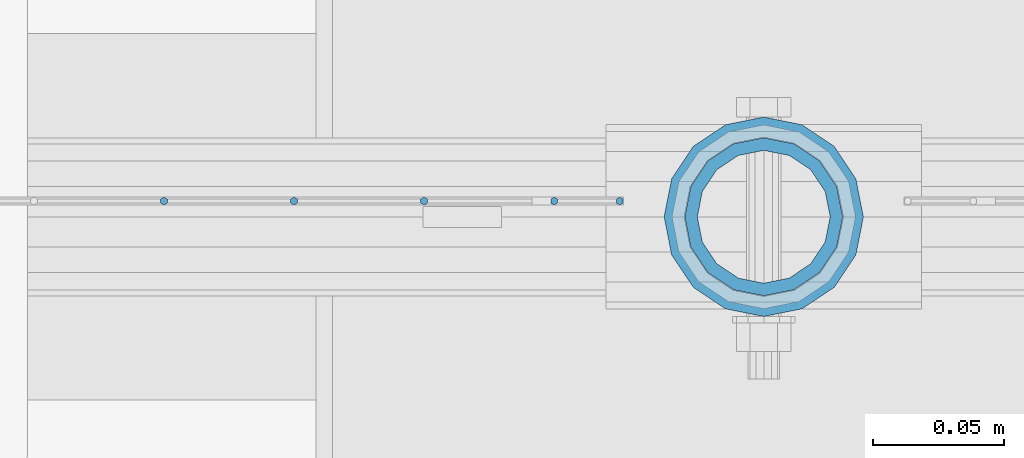
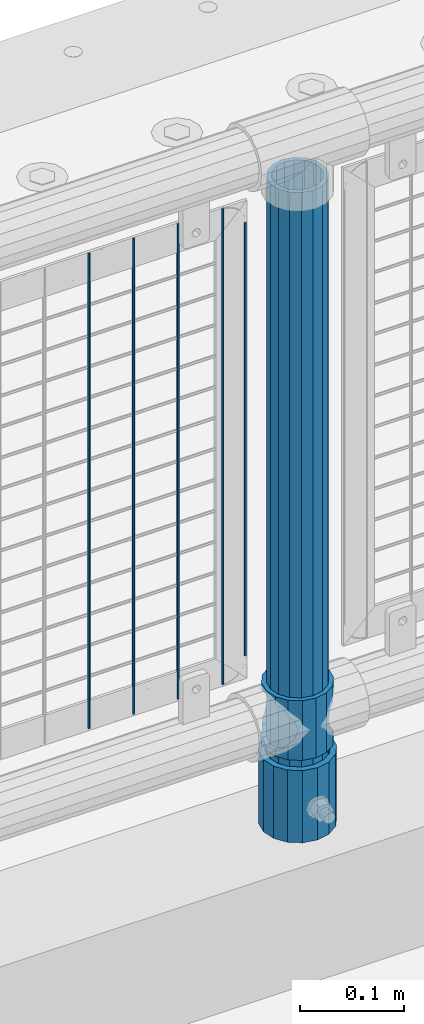
# One storey, part 68 of 257: 8 columns.
"""IFC2X3 building model written with IfcOpenShell, lengths in millimetres."""

from ifc_helpers import new_model, si_unit, frame, origin_with_axes, place, context, subcontext, project, spatial, faceted_brep, material, type_object, element, save


model = new_model("IFC2X3")

# Units and contexts
model_context = context("Model", 3, precision=1e-05, world=origin_with_axes())
body_context = subcontext(model_context, "Body", "Model", "MODEL_VIEW")
ifc_project = project(units=[si_unit("LENGTHUNIT", "METRE", prefix="MILLI"), si_unit("AREAUNIT", "SQUARE_METRE"), si_unit("VOLUMEUNIT", "CUBIC_METRE"), si_unit("MASSUNIT", "GRAM", prefix="KILO"), si_unit("TIMEUNIT", "SECOND"), si_unit("PLANEANGLEUNIT", "RADIAN"), si_unit("SOLIDANGLEUNIT", "STERADIAN"), si_unit("THERMODYNAMICTEMPERATUREUNIT", "DEGREE_CELSIUS"), si_unit("LUMINOUSINTENSITYUNIT", "LUMEN")], contexts=[model_context])

# Site, building, storey
site_placement = place(None, origin_with_axes())
site = spatial("IfcSite", under=ifc_project, at=site_placement, CompositionType="ELEMENT")
building_placement = place(site_placement, origin_with_axes())
building = spatial("IfcBuilding", under=site, at=building_placement, Name="Standard", CompositionType="ELEMENT")
storey_placement = place(building_placement, origin_with_axes())
storey = spatial("IfcBuildingStorey", under=building, at=storey_placement, Name="Undefined", CompositionType="ELEMENT", Elevation=0.0)

# Columns
ifc_material_1 = material()
column_type_1 = type_object("IfcColumnType", PredefinedType="NOTDEFINED")
column_1_placement = place(storey_placement, frame((44671.0, 10664.5, 168.02), z_axis=(0.0, 1.0, 0.0), x_axis=(0.0, 0.0, 1.0)))
element("IfcColumn", 1, at=column_1_placement, inside=storey, type_object=column_type_1, material=ifc_material_1, context=body_context, shape_type="Brep", body=[
    faceted_brep([(0.0, -31.75, 0.0), (0.0, -29.3331751572332, 12.1501989775916), (85.0, -29.3331751572332, 12.1501989775916), (85.0, -31.75, 0.0), (0.0, -22.4506403026753, 22.4506403026735), (85.0, -22.4506403026753, 22.4506403026735), (0.0, -12.1501989775934, 29.3331751572332), (85.0, -12.1501989775934, 29.3331751572332), (0.0, 0.0, 31.75), (85.0, 0.0, 31.75), (0.0, 12.1501989775934, 29.3331751572332), (85.0, 12.1501989775934, 29.3331751572332), (0.0, 22.4506403026753, 22.4506403026735), (85.0, 22.4506403026753, 22.4506403026735), (0.0, 29.3331751572332, 12.1501989775916), (85.0, 29.3331751572332, 12.1501989775916), (0.0, 31.75, 0.0), (85.0, 31.75, 0.0), (0.0, 29.3331751572332, -12.1501989775916), (85.0, 29.3331751572332, -12.1501989775916), (0.0, 22.4506403026753, -22.4506403026735), (85.0, 22.4506403026753, -22.4506403026735), (0.0, 12.1501989775934, -29.3331751572332), (85.0, 12.1501989775934, -29.3331751572332), (0.0, 0.0, -31.75), (85.0, 0.0, -31.75), (0.0, -12.1501989775934, -29.3331751572332), (85.0, -12.1501989775934, -29.3331751572332), (0.0, -22.4506403026753, -22.4506403026735), (85.0, -22.4506403026753, -22.4506403026735), (0.0, -29.3331751572332, -12.1501989775916), (85.0, -29.3331751572332, -12.1501989775916), (0.0, -38.0500000000029, 0.0), (0.0, -35.1536162120537, -14.561104601491), (85.0, -35.1536162120537, -14.561104601491), (85.0, -38.0500000000029, 0.0), (0.0, -26.9054130241493, -26.9054130241475), (85.0, -26.9054130241493, -26.9054130241475), (0.0, -14.5611046014892, -35.1536162120537), (85.0, -14.5611046014892, -35.1536162120537), (0.0, 0.0, -38.0499999999993), (85.0, 0.0, -38.0499999999993), (0.0, 14.5611046014892, -35.1536162120537), (85.0, 14.5611046014892, -35.1536162120537), (0.0, 26.9054130241493, -26.9054130241475), (85.0, 26.9054130241493, -26.9054130241475), (0.0, 35.1536162120537, -14.561104601491), (85.0, 35.1536162120537, -14.561104601491), (0.0, 38.0500000000029, 0.0), (85.0, 38.0500000000029, 0.0), (0.0, 35.1536162120537, 14.561104601491), (85.0, 35.1536162120537, 14.561104601491), (0.0, 26.9054130241493, 26.9054130241475), (85.0, 26.9054130241493, 26.9054130241475), (0.0, 14.5611046014892, 35.1536162120537), (85.0, 14.5611046014892, 35.1536162120537), (0.0, 0.0, 38.0499999999993), (85.0, 0.0, 38.0499999999993), (0.0, -14.5611046014892, 35.1536162120537), (85.0, -14.5611046014892, 35.1536162120537), (0.0, -26.9054130241493, 26.9054130241475), (85.0, -26.9054130241493, 26.9054130241475), (0.0, -35.1536162120537, 14.561104601491), (85.0, -35.1536162120537, 14.561104601491)], [[[0, 1, 2, 3]], [[1, 4, 5, 2]], [[4, 6, 7, 5]], [[6, 8, 9, 7]], [[8, 10, 11, 9]], [[10, 12, 13, 11]], [[12, 14, 15, 13]], [[14, 16, 17, 15]], [[16, 18, 19, 17]], [[18, 20, 21, 19]], [[20, 22, 23, 21]], [[22, 24, 25, 23]], [[24, 26, 27, 25]], [[26, 28, 29, 27]], [[28, 30, 31, 29]], [[30, 0, 3, 31]], [[32, 33, 34, 35]], [[33, 36, 37, 34]], [[36, 38, 39, 37]], [[38, 40, 41, 39]], [[40, 42, 43, 41]], [[42, 44, 45, 43]], [[44, 46, 47, 45]], [[46, 48, 49, 47]], [[48, 50, 51, 49]], [[50, 52, 53, 51]], [[52, 54, 55, 53]], [[54, 56, 57, 55]], [[56, 58, 59, 57]], [[58, 60, 61, 59]], [[60, 62, 63, 61]], [[62, 32, 35, 63]], [[37, 39, 41, 43, 45, 47, 49, 51, 53, 55, 57, 59, 61, 63, 35, 34], [5, 7, 9, 11, 13, 15, 17, 19, 21, 23, 25, 27, 29, 31, 3, 2]], [[62, 60, 58, 56, 54, 52, 50, 48, 46, 44, 42, 40, 38, 36, 33, 32], [30, 28, 26, 24, 22, 20, 18, 16, 14, 12, 10, 8, 6, 4, 1, 0]]]),
])
ifc_material_2 = material(Name="Misc_Undefined")
column_type_2 = type_object("IfcColumnType", PredefinedType="NOTDEFINED")
column_2_placement = place(storey_placement, frame((44671.0, 10664.5, 263.02), z_axis=(-1.0, 0.0, 0.0), x_axis=(0.0, 0.0, 1.0)))
element("IfcColumn", 2, at=column_2_placement, inside=storey, type_object=column_type_2, material=ifc_material_2, context=body_context, shape_type="Brep", body=[
    faceted_brep([(63.1897438117172, 11.6144421722802, -32.8397438117245), (63.1897438117172, 11.6144421722802, -28.0397438117143), (56.6106908090114, 21.4606908090118, -21.4606908090136), (56.6106908090114, 21.4606908090118, -27.1226768591077), (61.9623795176756, 13.4513226476338, -32.4743655677739), (46.7644421722801, 28.0397438117179, -11.6144421722784), (46.7644421722801, 28.0397438117179, -20.0882031229921), (51.5310424080039, 24.8548033587067, -24.8548033587067), (35.1500000000015, 30.35, 0.0), (35.1499999999996, 30.3500000000004, -16.6306603983758), (23.5355578277192, 28.0397438117179, -11.6144421722784), (23.5355578277192, 28.0397438117179, -20.0882031229921), (18.7689575919954, 24.8548033587067, -24.8548033587067), (13.6893091909879, 21.4606908090118, -21.4606908090136), (13.6893091909879, 21.4606908090118, -27.1226768591077), (8.3376204823237, 13.4513226476338, -32.4743655677739), (7.11025618828211, 11.6144421722802, -28.0397438117143), (7.11025618828211, 11.6144421722802, -32.8397438117245), (4.79999999999961, 0.0, -30.3499999999985), (4.79999999999961, 0.0, -35.1500000000015), (7.11025618828205, -11.6144421722802, -28.0397438117143), (7.11025618828205, -11.6144421722802, -32.8397438117245), (13.6893091909879, -21.4606908090118, -21.4606908090136), (13.6893091909879, -21.4606908090118, -27.1226768591077), (8.33762048232484, -13.4513226476338, -32.4743655677739), (23.5355578277191, -28.0397438117179, -11.6144421722784), (23.5355578277191, -28.0397438117179, -20.0882031229849), (18.7689575919987, -24.8548033587067, -24.8548033587067), (35.1500000000015, -30.35, 0.0), (35.1499999999996, -30.3500000000004, -16.6306603983685), (46.7644421722801, -28.0397438117179, -11.6144421722784), (46.7644421722801, -28.0397438117179, -20.0882031229849), (51.5310424080038, -24.8548033587067, -24.8548033587067), (56.6106908090114, -21.4606908090118, -21.4606908090136), (56.6106908090114, -21.4606908090118, -27.1226768591077), (61.9623795176756, -13.4513226476338, -32.4743655677739), (63.1897438117172, -11.6144421722802, -28.0397438117143), (63.1897438117172, -11.6144421722802, -32.8397438117245), (65.4999999999997, 0.0, -30.3499999999985), (65.4999999999997, 0.0, -35.1500000000015), (0.0, -28.0397438117179, -11.6144421722784), (0.0, -30.3500000000004, 0.0), (0.0, -21.4606908090118, -21.4606908090136), (0.0, -11.6144421722802, -28.0397438117143), (0.0, 0.0, -30.3499999999985), (0.0, 11.6144421722802, -28.0397438117143), (0.0, 21.4606908090118, -21.4606908090136), (0.0, 28.0397438117179, -11.6144421722784), (0.0, 30.3500000000004, 0.0), (0.0, 28.0397438117179, 11.6144421722784), (23.5355578277192, 28.0397438117179, 11.6144421722784), (0.0, 21.4606908090118, 21.4606908090136), (13.6893091909879, 21.4606908090118, 21.4606908090136), (0.0, 11.6144421722802, 28.0397438117143), (7.11025618828211, 11.6144421722802, 28.0397438117143), (0.0, 0.0, 30.3499999999985), (4.79999999999961, 0.0, 30.3499999999985), (0.0, -11.6144421722802, 28.0397438117143), (7.11025618828205, -11.6144421722802, 28.0397438117143), (0.0, -21.4606908090118, 21.4606908090136), (13.6893091909879, -21.4606908090118, 21.4606908090136), (0.0, -28.0397438117179, 11.6144421722784), (23.5355578277191, -28.0397438117179, 11.6144421722784), (0.0, -32.4743655677721, 13.4513226476338), (0.0, -35.1499999999996, 0.0), (70.2999999999993, -35.1499999999996, 0.0), (70.2999999999993, -32.4743655677721, 13.4513226476338), (0.0, 13.4513226476338, -32.4743655677739), (0.0, 24.8548033587067, -24.8548033587067), (0.0, 0.0, -35.1499999999996), (0.0, -13.4513226476338, -32.4743655677739), (0.0, -24.8548033587067, -24.8548033587067), (0.0, -24.8548033587067, 24.8548033587067), (0.0, -13.4513226476338, 32.4743655677739), (0.0, 0.0, 35.1499999999996), (0.0, 13.4513226476338, 32.4743655677739), (0.0, 24.8548033587067, 24.8548033587067), (0.0, 32.4743655677721, 13.4513226476338), (0.0, 35.1499999999996, 0.0), (0.0, 32.4743655677721, -13.4513226476338), (0.0, -32.4743655677721, -13.4513226476338), (70.2999999999993, 32.4743655677721, 13.4513226476338), (70.2999999999993, 35.1499999999996, 0.0), (70.2999999999993, 32.4743655677721, -13.4513226476338), (70.2999999999993, 24.8548033587067, -24.8548033587067), (70.2999999999993, 13.4513226476338, -32.4743655677739), (70.2999999999993, 0.0, -35.1500000000015), (70.2999999999993, -13.4513226476338, -32.4743655677739), (70.2999999999993, -24.8548033587067, -24.8548033587067), (70.2999999999993, -32.4743655677721, -13.4513226476338), (70.2999999999993, 28.0397438117179, 11.6144421722784), (70.2999999999993, 21.4606908090118, 21.4606908090136), (56.6106908090114, 21.4606908090118, 21.4606908090136), (46.7644421722801, 28.0397438117179, 11.6144421722784), (70.2999999999993, 11.6144421722802, 28.0397438117143), (63.1897438117172, 11.6144421722802, 28.0397438117143), (70.2999999999993, 0.0, 30.3499999999985), (65.4999999999997, 0.0, 30.3499999999985), (70.2999999999993, -11.6144421722802, 28.0397438117143), (63.1897438117172, -11.6144421722802, 28.0397438117143), (70.2999999999993, -21.4606908090118, 21.4606908090136), (56.6106908090114, -21.4606908090118, 21.4606908090136), (70.2999999999993, -28.0397438117179, 11.6144421722784), (46.7644421722801, -28.0397438117179, 11.6144421722784), (70.2999999999993, -11.6144421722802, -28.0397438117143), (70.2999999999993, 0.0, -30.3499999999985), (70.2999999999993, -21.4606908090118, -21.4606908090136), (70.2999999999993, -28.0397438117179, -11.6144421722784), (70.2999999999993, -30.3500000000004, 0.0), (70.2999999999993, 24.8548033587067, 24.8548033587067), (70.2999999999993, 13.4513226476338, 32.4743655677739), (70.2999999999993, 0.0, 35.1500000000015), (70.2999999999993, -13.4513226476338, 32.4743655677739), (70.2999999999993, -24.8548033587067, 24.8548033587067), (70.2999999999993, 30.3500000000004, 0.0), (70.2999999999993, 28.0397438117179, -11.6144421722784), (70.2999999999993, 21.4606908090118, -21.4606908090136), (70.2999999999993, 11.6144421722802, -28.0397438117143), (61.9623795176756, 13.4513226476338, 32.4743655677739), (51.5310424080039, 24.8548033587067, 24.8548033587067), (56.6106908090114, 21.4606908090118, 27.1226768591077), (65.4999999999997, 0.0, 35.1500000000015), (63.1897438117172, 11.6144421722802, 32.8397438117172), (63.1897438117172, -11.6144421722802, 32.8397438117172), (61.9623795176756, -13.4513226476338, 32.4743655677739), (56.6106908090114, -21.4606908090118, 27.1226768591077), (51.5310424080071, -24.8548033587067, 24.8548033587067), (18.7689575919987, -24.8548033587067, 24.8548033587067), (46.7644421722801, -28.0397438117179, 20.0882031229703), (35.1499999999996, -30.3500000000004, 16.6306603983539), (23.5355578277191, -28.0397438117179, 20.0882031229703), (8.3376204823237, -13.4513226476338, 32.4743655677739), (13.6893091909879, -21.4606908090118, 27.1226768591077), (4.79999999999961, 0.0, 35.1500000000015), (7.11025618828205, -11.6144421722802, 32.8397438117172), (7.11025618828211, 11.6144421722802, 32.8397438117172), (8.3376204823237, 13.4513226476338, 32.4743655677739), (13.6893091909879, 21.4606908090118, 27.1226768591077), (18.7689575919954, 24.8548033587067, 24.8548033587067), (23.5355578277192, 28.0397438117179, 20.0882031229849), (35.1499999999996, 30.3500000000004, 16.6306603983685), (46.7644421722801, 28.0397438117179, 20.0882031229849)], [[[0, 1, 2, 3, 4]], [[3, 2, 5, 6, 7]], [[6, 5, 8, 9]], [[9, 8, 10, 11]], [[12, 11, 10, 13, 14]], [[15, 14, 13, 16, 17]], [[17, 16, 18, 19]], [[19, 18, 20, 21]], [[21, 20, 22, 23, 24]], [[23, 22, 25, 26, 27]], [[26, 25, 28, 29]], [[29, 28, 30, 31]], [[32, 31, 30, 33, 34]], [[35, 34, 33, 36, 37]], [[37, 36, 38, 39]], [[39, 38, 1, 0]], [[40, 41, 28, 25]], [[42, 40, 25, 22]], [[43, 42, 22, 20]], [[44, 43, 20, 18]], [[45, 44, 18, 16]], [[46, 45, 16, 13]], [[47, 46, 13, 10]], [[48, 47, 10, 8]], [[49, 48, 8, 50]], [[51, 49, 50, 52]], [[53, 51, 52, 54]], [[55, 53, 54, 56]], [[57, 55, 56, 58]], [[59, 57, 58, 60]], [[61, 59, 60, 62]], [[41, 61, 62, 28]], [[63, 64, 65, 66]], [[67, 68, 12, 14, 15]], [[69, 67, 15, 17, 19]], [[24, 70, 69, 19, 21]], [[27, 71, 70, 24, 23]], [[63, 72, 73, 74, 75, 76, 77, 78, 79, 68, 67, 69, 70, 71, 80, 64], [40, 42, 43, 44, 45, 46, 47, 48, 49, 51, 53, 55, 57, 59, 61, 41]], [[78, 77, 81, 82]], [[79, 78, 82, 83]], [[9, 11, 12, 68, 79, 83, 84, 7, 6]], [[7, 84, 85, 4, 3]], [[4, 85, 86, 39, 0]], [[87, 88, 32, 34, 35]], [[86, 87, 35, 37, 39]], [[88, 89, 80, 71, 27, 26, 29, 31, 32]], [[64, 80, 89, 65]], [[90, 91, 92, 93]], [[91, 94, 95, 92]], [[94, 96, 97, 95]], [[96, 98, 99, 97]], [[98, 100, 101, 99]], [[100, 102, 103, 101]], [[104, 105, 38, 36]], [[106, 104, 36, 33]], [[107, 106, 33, 30]], [[108, 107, 30, 28]], [[102, 108, 28, 103]], [[88, 87, 86, 85, 84, 83, 82, 81, 109, 110, 111, 112, 113, 66, 65, 89], [100, 98, 96, 94, 91, 90, 114, 115, 116, 117, 105, 104, 106, 107, 108, 102]], [[118, 110, 109, 119, 120]], [[121, 111, 110, 118, 122]], [[112, 111, 121, 123, 124]], [[113, 112, 124, 125, 126]], [[127, 72, 63, 66, 113, 126, 128, 129, 130]], [[131, 73, 72, 127, 132]], [[133, 74, 73, 131, 134]], [[75, 74, 133, 135, 136]], [[76, 75, 136, 137, 138]], [[119, 109, 81, 77, 76, 138, 139, 140, 141]], [[92, 120, 119, 141, 93]], [[95, 122, 118, 120, 92]], [[97, 121, 122, 95]], [[99, 123, 121, 97]], [[101, 125, 124, 123, 99]], [[103, 128, 126, 125, 101]], [[28, 129, 128, 103]], [[62, 130, 129, 28]], [[60, 132, 127, 130, 62]], [[58, 134, 131, 132, 60]], [[56, 133, 134, 58]], [[54, 135, 133, 56]], [[52, 137, 136, 135, 54]], [[50, 139, 138, 137, 52]], [[8, 140, 139, 50]], [[93, 141, 140, 8]], [[114, 90, 93, 8]], [[115, 114, 8, 5]], [[116, 115, 5, 2]], [[117, 116, 2, 1]], [[105, 117, 1, 38]]]),
])
column_type_3 = type_object("IfcColumnType", PredefinedType="NOTDEFINED")
column_3_placement = place(storey_placement, frame((44671.0, 10664.5, 168.02), z_axis=(-1.0, 0.0, 0.0), x_axis=(0.0, 0.0, 1.0)))
element("IfcColumn", 3, at=column_3_placement, inside=storey, type_object=column_type_3, material=ifc_material_1, context=body_context, shape_type="Brep", body=[
    faceted_brep([(0.0, -25.3500000000004, 0.0), (0.0, -23.4203461491616, 9.70102501045767), (760.0, -23.4203461491616, 9.70102501045767), (760.0, -25.3500000000004, 0.0), (0.0, -17.9251569030785, 17.9251569030821), (760.0, -17.9251569030785, 17.9251569030821), (0.0, -9.70102501045585, 23.4203461491634), (760.0, -9.70102501045585, 23.4203461491634), (0.0, 0.0, 25.3499999999985), (760.0, 0.0, 25.3499999999985), (0.0, 9.70102501045585, 23.4203461491634), (760.0, 9.70102501045585, 23.4203461491634), (0.0, 17.9251569030785, 17.9251569030821), (760.0, 17.9251569030785, 17.9251569030821), (0.0, 23.4203461491616, 9.70102501045767), (760.0, 23.4203461491616, 9.70102501045767), (0.0, 25.3500000000004, 0.0), (760.0, 25.3500000000004, 0.0), (0.0, 23.4203461491616, -9.70102501045767), (760.0, 23.4203461491616, -9.70102501045767), (0.0, 17.9251569030785, -17.9251569030821), (760.0, 17.9251569030785, -17.9251569030821), (0.0, 9.70102501045585, -23.4203461491634), (760.0, 9.70102501045585, -23.4203461491634), (0.0, 0.0, -25.3499999999985), (760.0, 0.0, -25.3499999999985), (0.0, -9.70102501045585, -23.4203461491634), (760.0, -9.70102501045585, -23.4203461491634), (0.0, -17.9251569030785, -17.9251569030821), (760.0, -17.9251569030785, -17.9251569030821), (0.0, -23.4203461491616, -9.70102501045767), (760.0, -23.4203461491616, -9.70102501045767), (0.0, -30.1499999999996, 0.0), (0.0, -27.8549679052157, -11.5379054858058), (760.0, -27.8549679052157, -11.5379054858058), (760.0, -30.1499999999996, 0.0), (0.0, -21.3192694527752, -21.3192694527752), (760.0, -21.3192694527752, -21.3192694527752), (0.0, -11.5379054858076, -27.8549679052157), (760.0, -11.5379054858076, -27.8549679052157), (0.0, 0.0, -30.1500000000015), (760.0, 0.0, -30.1500000000015), (0.0, 11.5379054858076, -27.8549679052157), (760.0, 11.5379054858076, -27.8549679052157), (0.0, 21.3192694527752, -21.3192694527752), (760.0, 21.3192694527752, -21.3192694527752), (0.0, 27.8549679052157, -11.5379054858058), (760.0, 27.8549679052157, -11.5379054858058), (0.0, 30.1499999999996, 0.0), (760.0, 30.1499999999996, 0.0), (0.0, 27.8549679052157, 11.5379054858058), (760.0, 27.8549679052157, 11.5379054858058), (0.0, 21.3192694527752, 21.3192694527752), (760.0, 21.3192694527752, 21.3192694527752), (0.0, 11.5379054858076, 27.8549679052157), (760.0, 11.5379054858076, 27.8549679052157), (0.0, 0.0, 30.1500000000015), (760.0, 0.0, 30.1500000000015), (0.0, -11.5379054858076, 27.8549679052157), (760.0, -11.5379054858076, 27.8549679052157), (0.0, -21.3192694527752, 21.3192694527752), (760.0, -21.3192694527752, 21.3192694527752), (0.0, -27.8549679052157, 11.5379054858058), (760.0, -27.8549679052157, 11.5379054858058)], [[[0, 1, 2, 3]], [[1, 4, 5, 2]], [[4, 6, 7, 5]], [[6, 8, 9, 7]], [[8, 10, 11, 9]], [[10, 12, 13, 11]], [[12, 14, 15, 13]], [[14, 16, 17, 15]], [[16, 18, 19, 17]], [[18, 20, 21, 19]], [[20, 22, 23, 21]], [[22, 24, 25, 23]], [[24, 26, 27, 25]], [[26, 28, 29, 27]], [[28, 30, 31, 29]], [[30, 0, 3, 31]], [[32, 33, 34, 35]], [[33, 36, 37, 34]], [[36, 38, 39, 37]], [[38, 40, 41, 39]], [[40, 42, 43, 41]], [[42, 44, 45, 43]], [[44, 46, 47, 45]], [[46, 48, 49, 47]], [[48, 50, 51, 49]], [[50, 52, 53, 51]], [[52, 54, 55, 53]], [[54, 56, 57, 55]], [[56, 58, 59, 57]], [[58, 60, 61, 59]], [[60, 62, 63, 61]], [[62, 32, 35, 63]], [[37, 39, 41, 43, 45, 47, 49, 51, 53, 55, 57, 59, 61, 63, 35, 34], [5, 7, 9, 11, 13, 15, 17, 19, 21, 23, 25, 27, 29, 31, 3, 2]], [[62, 60, 58, 56, 54, 52, 50, 48, 46, 44, 42, 40, 38, 36, 33, 32], [30, 28, 26, 24, 22, 20, 18, 16, 14, 12, 10, 8, 6, 4, 1, 0]]]),
])
column_type_4 = type_object("IfcColumnType", Name="D3", PredefinedType="NOTDEFINED")
for number, where, z_axis, x_axis in (
    (4, (44590.995, 10670.5, 353.02), (-1.0, 0.0, 0.0), (0.0, 0.0, 1.0)),
    (5, (44541.34, 10670.5, 353.02), (-1.0, 0.0, 0.0), (0.0, 0.0, 1.0)),
    (6, (44491.685, 10670.5, 353.02), (-1.0, 0.0, 0.0), (0.0, 0.0, 1.0)),
    (7, (44442.03, 10670.5, 353.02), (-1.0, 0.0, 0.0), (0.0, 0.0, 1.0)),
):
    element("IfcColumn", number, at=place(storey_placement, frame(where, z_axis=z_axis, x_axis=x_axis)), inside=storey, type_object=column_type_4, material=ifc_material_2, ObjectType="D3", context=body_context, shape_type="Brep", body=[
        faceted_brep([(0.0, -1.5, -5.6843418860808e-14), (0.0, -0.750000000001819, -1.29903810567669), (560.0, -0.75, -1.29903810567339), (560.0, -1.5, 0.0), (7.27595761418343e-12, 0.749999999998181, -1.29903810567669), (560.0, 0.75, -1.29903810567339), (0.0, 1.5, -5.6843418860808e-14), (560.0, 1.5, 0.0), (7.27595761418343e-12, 0.749999999998181, 1.29903810567669), (560.0, 0.75, 1.29903810567339), (0.0, -0.750000000001819, 1.29903810567669), (560.0, -0.75, 1.29903810567339)], [[[0, 1, 2, 3]], [[1, 4, 5, 2]], [[4, 6, 7, 5]], [[6, 8, 9, 7]], [[8, 10, 11, 9]], [[10, 0, 3, 11]], [[5, 7, 9, 11, 3, 2]], [[10, 8, 6, 4, 1, 0]]]),
    ])
column_4_placement = place(storey_placement, frame((44616.0, 10670.5, 378.02), z_axis=(-1.0, 0.0, 0.0), x_axis=(0.0, 0.0, 1.0)))
element("IfcColumn", 8, at=column_4_placement, inside=storey, type_object=column_type_4, material=ifc_material_2, ObjectType="D3", context=body_context, shape_type="Brep", body=[
    faceted_brep([(0.0, -1.5, -5.6843418860808e-14), (0.0, -0.750000000001819, -1.29903810567669), (510.0, -0.75, -1.29903810567339), (510.0, -1.5, 0.0), (7.27595761418343e-12, 0.749999999998181, -1.29903810567669), (510.0, 0.75, -1.29903810567339), (0.0, 1.5, -5.6843418860808e-14), (510.0, 1.5, 0.0), (7.27595761418343e-12, 0.749999999998181, 1.29903810567669), (510.0, 0.75, 1.29903810567339), (0.0, -0.750000000001819, 1.29903810567669), (510.0, -0.75, 1.29903810567339)], [[[0, 1, 2, 3]], [[1, 4, 5, 2]], [[4, 6, 7, 5]], [[6, 8, 9, 7]], [[8, 10, 11, 9]], [[10, 0, 3, 11]], [[5, 7, 9, 11, 3, 2]], [[10, 8, 6, 4, 1, 0]]]),
])

save(model, "model.ifc")
